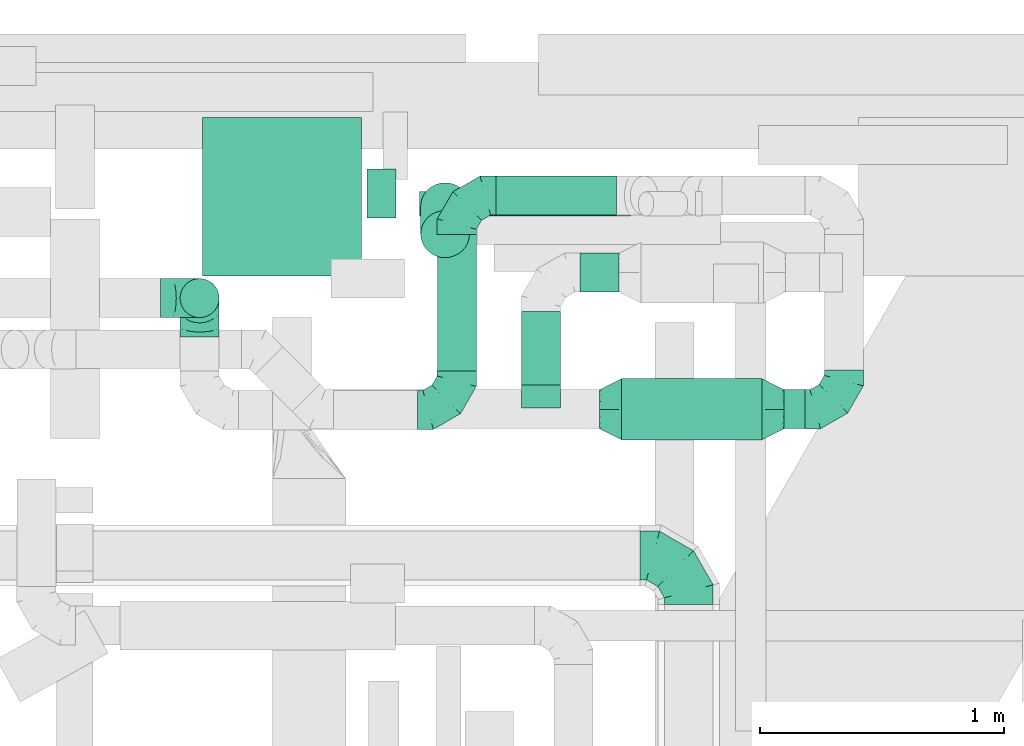
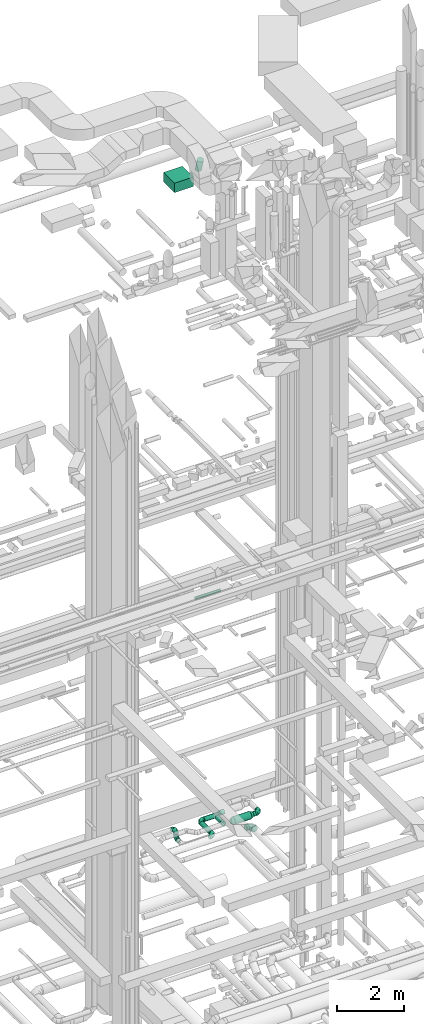
# One storey, part 287 of 337: 11 flow segments, 9 flow fittings.
"""IFC2X3 building model written with IfcOpenShell, lengths in millimetres."""

from ifc_helpers import new_model, entity, si_unit, converted_unit, derived_unit, direction, frame, origin, origin_2d_with_axis, place, context, subcontext, project, spatial, rectangle, circle, extrude, faceted_brep, source, transform, mapped, material, type_object, type_shapes, element, save


model = new_model("IFC2X3")

# Units and contexts
model_context = context("Model", 3, precision=0.01, world=origin(), true_north=direction((6.12303176911189e-17, 1.0)))
body_context = subcontext(model_context, "Body", "Model", "MODEL_VIEW")
ifc_project = project(units=[si_unit("LENGTHUNIT", "METRE", prefix="MILLI"), si_unit("AREAUNIT", "SQUARE_METRE"), si_unit("VOLUMEUNIT", "CUBIC_METRE"), converted_unit("PLANEANGLEUNIT", "DEGREE", entity("IfcRatioMeasure", 0.0174532925199433), si_unit("PLANEANGLEUNIT", "RADIAN"), dimensions=[0, 0, 0, 0, 0, 0, 0]), si_unit("MASSUNIT", "GRAM", prefix="KILO"), derived_unit("MASSDENSITYUNIT", [(si_unit("MASSUNIT", "GRAM", prefix="KILO"), 1), (si_unit("LENGTHUNIT", "METRE"), -3)]), derived_unit("MOMENTOFINERTIAUNIT", [(si_unit("LENGTHUNIT", "METRE"), 4)]), si_unit("TIMEUNIT", "SECOND"), si_unit("FREQUENCYUNIT", "HERTZ"), si_unit("THERMODYNAMICTEMPERATUREUNIT", "DEGREE_CELSIUS"), derived_unit("THERMALTRANSMITTANCEUNIT", [(si_unit("MASSUNIT", "GRAM", prefix="KILO"), 1), (si_unit("THERMODYNAMICTEMPERATUREUNIT", "KELVIN"), -1), (si_unit("TIMEUNIT", "SECOND"), -3)]), derived_unit("VOLUMETRICFLOWRATEUNIT", [(si_unit("LENGTHUNIT", "METRE"), 3), (si_unit("TIMEUNIT", "SECOND"), -1)]), derived_unit("MASSFLOWRATEUNIT", [(si_unit("MASSUNIT", "GRAM", prefix="KILO"), 1), (si_unit("TIMEUNIT", "SECOND"), -1)]), derived_unit("ROTATIONALFREQUENCYUNIT", [(si_unit("TIMEUNIT", "SECOND"), -1)]), si_unit("ELECTRICCURRENTUNIT", "AMPERE"), si_unit("ELECTRICVOLTAGEUNIT", "VOLT"), si_unit("POWERUNIT", "WATT"), si_unit("FORCEUNIT", "NEWTON", prefix="KILO"), si_unit("ILLUMINANCEUNIT", "LUX"), si_unit("LUMINOUSFLUXUNIT", "LUMEN"), si_unit("LUMINOUSINTENSITYUNIT", "CANDELA"), derived_unit("USERDEFINED", [(si_unit("MASSUNIT", "GRAM", prefix="KILO"), -1), (si_unit("LENGTHUNIT", "METRE"), -2), (si_unit("TIMEUNIT", "SECOND"), 3), (si_unit("LUMINOUSFLUXUNIT", "LUMEN"), 1)]), derived_unit("LINEARVELOCITYUNIT", [(si_unit("LENGTHUNIT", "METRE"), 1), (si_unit("TIMEUNIT", "SECOND"), -1)]), si_unit("PRESSUREUNIT", "PASCAL"), derived_unit("USERDEFINED", [(si_unit("LENGTHUNIT", "METRE"), -2), (si_unit("MASSUNIT", "GRAM", prefix="KILO"), 1), (si_unit("TIMEUNIT", "SECOND"), -2)]), derived_unit("LINEARFORCEUNIT", [(si_unit("MASSUNIT", "GRAM", prefix="KILO"), 1), (si_unit("LENGTHUNIT", "METRE"), 1), (si_unit("TIMEUNIT", "SECOND"), -2), (si_unit("LENGTHUNIT", "METRE"), -1)]), derived_unit("PLANARFORCEUNIT", [(si_unit("MASSUNIT", "GRAM", prefix="KILO"), 1), (si_unit("LENGTHUNIT", "METRE"), 1), (si_unit("TIMEUNIT", "SECOND"), -2), (si_unit("LENGTHUNIT", "METRE"), -2)])], contexts=[model_context])

# Site, building, storey
site_placement = place(None, origin())
site = spatial("IfcSite", under=ifc_project, at=site_placement, CompositionType="ELEMENT")
building_placement = place(site_placement, origin())
building = spatial("IfcBuilding", under=site, at=building_placement, CompositionType="ELEMENT")
storey_placement = place(building_placement, origin())
storey = spatial("IfcBuildingStorey", under=building, at=storey_placement, CompositionType="ELEMENT", Elevation=0.0)

# Flow segments
duct_segment_type_1 = type_object("IfcDuctSegmentType", PredefinedType="NOTDEFINED")
flow_segment_1_placement = place(storey_placement, frame((51398.48, 19108.98, 26700.0)))
element("IfcFlowSegment", 1, at=flow_segment_1_placement, inside=storey, type_object=duct_segment_type_1, context=body_context, shape_type="SweptSolid", body=[
    extrude(rectangle(XDim=650.0, YDim=650.0, at=origin_2d_with_axis()), frame((325.0, 325.0, 0.0)), (0.0, 0.0, 1.0), 349.999999999998),
])
duct_segment_type_2 = type_object("IfcDuctSegmentType", PredefinedType="NOTDEFINED")
flow_segment_2_placement = place(storey_placement, frame((52285.9, 19353.19, 11348.4)))
element("IfcFlowSegment", 2, at=flow_segment_2_placement, inside=storey, type_object=duct_segment_type_2, context=body_context, shape_type="SweptSolid", body=[
    extrude(circle(Radius=50.0, at=origin_2d_with_axis()), frame((0.0, 51.6, 51.6), z_axis=(1.0, 0.0, 0.0), x_axis=(0.0, 1.0, 0.0)), (0.0, 0.0, 1.0), 864.588142746948),
])
flow_segment_3_placement = place(storey_placement, frame((52289.06, 19183.14, 27014.73)))
element("IfcFlowSegment", 3, at=flow_segment_3_placement, inside=storey, type_object=duct_segment_type_2, context=body_context, shape_type="SweptSolid", body=[
    extrude(circle(Radius=100.0, at=origin_2d_with_axis()), frame((101.6, 211.95, 28.11), z_axis=(0.0, -0.265156483021046, 0.964205392803789), x_axis=(0.0, 0.964205392803789, 0.265156483021046)), (0.0, 0.0, 1.0), 429.698740507696),
])
flow_segment_4_placement = place(storey_placement, frame((52070.65, 19346.53, 26748.4)))
element("IfcFlowSegment", 4, at=flow_segment_4_placement, inside=storey, type_object=duct_segment_type_2, context=body_context, shape_type="SweptSolid", body=[
    extrude(circle(Radius=100.0, at=origin_2d_with_axis()), frame((0.0, 101.6, 101.6), z_axis=(1.0, 0.0, 0.0), x_axis=(0.0, 1.0, 0.0)), (0.0, 0.0, 1.0), 119.999999999999),
])
flow_segment_5_placement = place(storey_placement, frame((52356.74, 18721.61, 3118.4)))
element("IfcFlowSegment", 5, at=flow_segment_5_placement, inside=storey, type_object=duct_segment_type_2, context=body_context, shape_type="SweptSolid", body=[
    extrude(circle(Radius=80.0, at=origin_2d_with_axis()), frame((81.6, 0.0, 81.6), z_axis=(0.0, 1.0, 0.0), x_axis=(1.0, 0.0, 0.0)), (0.0, 0.0, 1.0), 557.500000000003),
])
flow_segment_6_placement = place(storey_placement, frame((51304.24, 18937.52, 3360.0)))
element("IfcFlowSegment", 6, at=flow_segment_6_placement, inside=storey, type_object=duct_segment_type_2, context=body_context, shape_type="SweptSolid", body=[
    extrude(circle(Radius=80.0, at=origin_2d_with_axis()), frame((81.6, 81.6, 0.0)), (0.0, 0.0, 1.0), 30.0000000000083),
])
flow_segment_7_placement = place(storey_placement, frame((52598.34, 19357.52, 3118.4)))
element("IfcFlowSegment", 7, at=flow_segment_7_placement, inside=storey, type_object=duct_segment_type_2, context=body_context, shape_type="SweptSolid", body=[
    extrude(circle(Radius=80.0, at=origin_2d_with_axis()), frame((0.0, 81.6, 81.6), z_axis=(1.0, 0.0, 0.0), x_axis=(0.0, -1.0, 0.0)), (0.0, 0.0, 1.0), 493.725830020317),
])
flow_segment_8_placement = place(storey_placement, frame((53778.34, 18482.52, 3418.4)))
element("IfcFlowSegment", 8, at=flow_segment_8_placement, inside=storey, type_object=duct_segment_type_2, context=body_context, shape_type="SweptSolid", body=[
    extrude(circle(Radius=80.0, at=origin_2d_with_axis()), frame((0.0, 81.6, 81.6), z_axis=(1.0, 0.0, 0.0), x_axis=(0.0, 1.0, 0.0)), (0.0, 0.0, 1.0), 85.0000000000153),
])
flow_segment_9_placement = place(storey_placement, frame((53113.34, 18437.52, 3373.4)))
element("IfcFlowSegment", 9, at=flow_segment_9_placement, inside=storey, type_object=duct_segment_type_2, context=body_context, shape_type="SweptSolid", body=[
    extrude(circle(Radius=125.0, at=origin_2d_with_axis()), frame((0.0, 126.6, 126.6), z_axis=(1.0, 0.0, 0.0), x_axis=(0.0, 1.0, 0.0)), (0.0, 0.0, 1.0), 574.999999999991),
])
flow_segment_10_placement = place(storey_placement, frame((52943.34, 19041.81, 3418.4)))
element("IfcFlowSegment", 10, at=flow_segment_10_placement, inside=storey, type_object=duct_segment_type_2, context=body_context, shape_type="SweptSolid", body=[
    extrude(circle(Radius=80.0, at=origin_2d_with_axis()), frame((0.0, 81.6, 81.6), z_axis=(1.0, 0.0, 0.0), x_axis=(0.0, 1.0, 0.0)), (0.0, 0.0, 1.0), 160.000000000016),
])
flow_segment_11_placement = place(storey_placement, frame((52701.74, 18664.11, 3418.4)))
element("IfcFlowSegment", 11, at=flow_segment_11_placement, inside=storey, type_object=duct_segment_type_2, context=body_context, shape_type="SweptSolid", body=[
    extrude(circle(Radius=80.0, at=origin_2d_with_axis()), frame((81.6, 0.0, 81.6), z_axis=(0.0, 1.0, 0.0), x_axis=(-1.0, 0.0, 0.0)), (0.0, 0.0, 1.0), 299.297970592642),
])

# Flow fittings
ifc_material = material()
duct_fitting_type_1 = type_object("IfcDuctFittingType", PredefinedType="NOTDEFINED", material=ifc_material)
shared_shape_1 = source(origin(), body_context, "Body", "Brep", [
    faceted_brep([(-160.0, 0.0, -80.0), (-160.0, -20.71, -77.27), (-160.0, -40.0, -69.28), (-160.0, -56.57, -56.57), (-160.0, -69.28, -40.0), (-160.0, -77.27, -20.71), (-160.0, -80.0, 0.0), (-160.0, -77.27, 20.71), (-160.0, -69.28, 40.0), (-160.0, -56.57, 56.57), (-160.0, -40.0, 69.28), (-160.0, -20.71, 77.27), (-160.0, 0.0, 80.0), (-160.0, 20.71, 77.27), (-160.0, 40.0, 69.28), (-160.0, 56.57, 56.57), (-160.0, 69.28, 40.0), (-160.0, 77.27, 20.71), (-160.0, 80.0, 0.0), (-160.0, 77.27, -20.71), (-160.0, 69.28, -40.0), (-160.0, 56.57, -56.57), (-160.0, 40.0, -69.28), (-160.0, 20.71, -77.27), (-122.68, 20.71, 77.27), (-127.85, 40.0, 69.28), (-117.13, 0.0, 80.0), (-132.29, 56.57, 56.57), (-137.83, 77.27, 20.71), (-138.56, 80.0, 0.0), (-135.69, 69.28, 40.0), (-135.69, 69.28, -40.0), (-132.29, 56.57, -56.57), (-137.83, 77.27, -20.71), (-122.68, 20.71, -77.27), (-117.13, 0.0, -80.0), (-127.85, 40.0, -69.28), (-111.58, -20.71, -77.27), (-106.41, -40.0, -69.28), (-101.97, -56.57, -56.57), (-98.56, -69.28, -40.0), (-96.42, -77.27, -20.71), (-95.69, -80.0, 0.0), (-96.42, -77.27, 20.71), (-98.56, -69.28, 40.0), (-101.97, -56.57, 56.57), (-106.41, -40.0, 69.28), (-111.58, -20.71, 77.27), (-58.03, 58.03, 77.27), (-72.15, 72.15, 69.28), (-42.87, 42.87, 80.0), (-84.28, 84.28, 56.57), (-93.59, 93.59, 40.0), (-99.44, 99.44, 20.71), (-101.44, 101.44, 0.0), (-99.44, 99.44, -20.71), (-93.59, 93.59, -40.0), (-84.28, 84.28, -56.57), (-58.03, 58.03, -77.27), (-42.87, 42.87, -80.0), (-72.15, 72.15, -69.28), (-27.71, 27.71, -77.27), (-13.59, 13.59, -69.28), (-1.46, 1.46, -56.57), (7.85, -7.85, -40.0), (13.7, -13.7, -20.71), (15.69, -15.69, 0.0), (13.7, -13.7, 20.71), (7.85, -7.85, 40.0), (-1.46, 1.46, 56.57), (-13.59, 13.59, 69.28), (-27.71, 27.71, 77.27), (-20.71, 122.68, 77.27), (-40.0, 127.85, 69.28), (0.0, 117.13, 80.0), (-56.57, 132.29, 56.57), (-69.28, 135.69, 40.0), (-77.27, 137.83, 20.71), (-80.0, 138.56, 0.0), (-77.27, 137.83, -20.71), (-69.28, 135.69, -40.0), (-56.57, 132.29, -56.57), (-20.71, 122.68, -77.27), (0.0, 117.13, -80.0), (-40.0, 127.85, -69.28), (20.71, 111.58, -77.27), (40.0, 106.41, -69.28), (56.57, 101.97, -56.57), (69.28, 98.56, -40.0), (77.27, 96.42, -20.71), (80.0, 95.69, 0.0), (77.27, 96.42, 20.71), (69.28, 98.56, 40.0), (56.57, 101.97, 56.57), (40.0, 106.41, 69.28), (20.71, 111.58, 77.27), (-20.71, 160.0, -77.27), (-40.0, 160.0, -69.28), (-56.57, 160.0, -56.57), (-69.28, 160.0, -40.0), (-77.27, 160.0, -20.71), (-80.0, 160.0, 0.0), (-77.27, 160.0, 20.71), (-69.28, 160.0, 40.0), (-56.57, 160.0, 56.57), (-40.0, 160.0, 69.28), (-20.71, 160.0, 77.27), (0.0, 160.0, 80.0), (20.71, 160.0, 77.27), (40.0, 160.0, 69.28), (56.57, 160.0, 56.57), (69.28, 160.0, 40.0), (77.27, 160.0, 20.71), (80.0, 160.0, 0.0), (77.27, 160.0, -20.71), (69.28, 160.0, -40.0), (56.57, 160.0, -56.57), (40.0, 160.0, -69.28), (20.71, 160.0, -77.27), (0.0, 160.0, -80.0)], [[[0, 1, 2, 3, 4, 5, 6, 7, 8, 9, 10, 11, 12, 13, 14, 15, 16, 17, 18, 19, 20, 21, 22, 23]], [[24, 25, 14, 13]], [[26, 24, 13, 12]], [[14, 25, 27, 15]], [[28, 29, 18, 17]], [[30, 28, 17, 16]], [[15, 27, 30, 16]], [[20, 31, 32, 21]], [[33, 31, 20, 19]], [[18, 29, 33, 19]], [[34, 35, 0, 23]], [[36, 34, 23, 22]], [[32, 36, 22, 21]], [[1, 0, 35, 37]], [[2, 1, 37, 38]], [[3, 2, 38, 39]], [[5, 4, 40, 41]], [[6, 5, 41, 42]], [[39, 40, 4, 3]], [[6, 42, 43, 7]], [[7, 43, 44, 8]], [[8, 44, 45, 9]], [[9, 45, 46, 10]], [[10, 46, 47, 11]], [[26, 12, 11, 47]], [[48, 49, 25, 24]], [[50, 48, 24, 26]], [[27, 25, 49, 51]], [[52, 53, 28, 30]], [[51, 52, 30, 27]], [[29, 28, 53, 54]], [[55, 56, 31, 33]], [[54, 55, 33, 29]], [[32, 31, 56, 57]], [[58, 59, 35, 34]], [[60, 58, 34, 36]], [[57, 60, 36, 32]], [[37, 35, 59, 61]], [[38, 37, 61, 62]], [[39, 38, 62, 63]], [[41, 40, 64, 65]], [[42, 41, 65, 66]], [[63, 64, 40, 39]], [[43, 42, 66, 67]], [[44, 43, 67, 68]], [[68, 69, 45, 44]], [[46, 45, 69, 70]], [[47, 46, 70, 71]], [[26, 47, 71, 50]], [[72, 73, 49, 48]], [[74, 72, 48, 50]], [[51, 49, 73, 75]], [[76, 77, 53, 52]], [[75, 76, 52, 51]], [[54, 53, 77, 78]], [[79, 80, 56, 55]], [[78, 79, 55, 54]], [[57, 56, 80, 81]], [[82, 83, 59, 58]], [[84, 82, 58, 60]], [[81, 84, 60, 57]], [[61, 59, 83, 85]], [[62, 61, 85, 86]], [[63, 62, 86, 87]], [[65, 64, 88, 89]], [[66, 65, 89, 90]], [[87, 88, 64, 63]], [[67, 66, 90, 91]], [[68, 67, 91, 92]], [[92, 93, 69, 68]], [[70, 69, 93, 94]], [[71, 70, 94, 95]], [[50, 71, 95, 74]], [[96, 97, 98, 99, 100, 101, 102, 103, 104, 105, 106, 107, 108, 109, 110, 111, 112, 113, 114, 115, 116, 117, 118, 119]], [[72, 74, 107, 106]], [[73, 72, 106, 105]], [[75, 73, 105, 104]], [[77, 76, 103, 102]], [[78, 77, 102, 101]], [[75, 104, 103, 76]], [[78, 101, 100, 79]], [[79, 100, 99, 80]], [[80, 99, 98, 81]], [[84, 97, 96, 82]], [[82, 96, 119, 83]], [[84, 81, 98, 97]], [[118, 117, 86, 85]], [[119, 118, 85, 83]], [[116, 87, 86, 117]], [[88, 115, 114, 89]], [[89, 114, 113, 90]], [[115, 88, 87, 116]], [[112, 111, 92, 91]], [[113, 112, 91, 90]], [[111, 110, 93, 92]], [[95, 94, 109, 108]], [[74, 95, 108, 107]], [[110, 109, 94, 93]]]),
])
type_shapes(duct_fitting_type_1, [shared_shape_1])
flow_fitting_1_placement = place(storey_placement, frame((52438.34, 18561.61, 3200.0)))
element("IfcFlowFitting", 12, at=flow_fitting_1_placement, inside=storey, type_object=duct_fitting_type_1, material=ifc_material, context=body_context, shape_type="MappedRepresentation", body=[
    mapped(shared_shape_1, transform((0.0, 0.0, 0.0), scale=1.0)),
])
for number, where, z_axis, x_axis in (
    (13, (52438.34, 19439.11, 3200.0), (0.0, 0.0, 1.0), (-1.0, 0.0, 0.0)),
    (14, (51385.84, 19019.11, 3550.0), (0.0, 1.0, 0.0), (1.0, 0.0, 0.0)),
    (15, (51385.84, 19019.11, 3200.0), (1.0, 0.0, 0.0), (0.0, 1.0, 0.0)),
):
    element("IfcFlowFitting", number, at=place(storey_placement, frame(where, z_axis=z_axis, x_axis=x_axis)), inside=storey, type_object=duct_fitting_type_1, material=ifc_material, context=body_context, shape_type="MappedRepresentation", body=[
        mapped(shared_shape_1, transform((0.0, 0.0, 0.0), scale=1.0)),
    ])
flow_fitting_2_placement = place(storey_placement, frame((54023.34, 18564.11, 3500.0)))
element("IfcFlowFitting", 16, at=flow_fitting_2_placement, inside=storey, type_object=duct_fitting_type_1, material=ifc_material, context=body_context, shape_type="MappedRepresentation", body=[
    mapped(shared_shape_1, transform((0.0, 0.0, 0.0), scale=1.0)),
])
duct_fitting_type_2 = type_object("IfcDuctFittingType", PredefinedType="NOTDEFINED", material=ifc_material)
shared_shape_2 = source(origin(), body_context, "Body", "Brep", [
    faceted_brep([(-200.0, 0.0, -100.0), (-200.0, -25.88, -96.59), (-200.0, -50.0, -86.6), (-200.0, -70.71, -70.71), (-200.0, -86.6, -50.0), (-200.0, -96.59, -25.88), (-200.0, -100.0, 0.0), (-200.0, -96.59, 25.88), (-200.0, -86.6, 50.0), (-200.0, -70.71, 70.71), (-200.0, -50.0, 86.6), (-200.0, -25.88, 96.59), (-200.0, 0.0, 100.0), (-200.0, 25.88, 96.59), (-200.0, 50.0, 86.6), (-200.0, 70.71, 70.71), (-200.0, 86.6, 50.0), (-200.0, 96.59, 25.88), (-200.0, 100.0, 0.0), (-200.0, 96.59, -25.88), (-200.0, 86.6, -50.0), (-200.0, 70.71, -70.71), (-200.0, 50.0, -86.6), (-200.0, 25.88, -96.59), (-153.35, 25.88, 96.59), (-159.81, 50.0, 86.6), (-146.41, 0.0, 100.0), (-165.36, 70.71, 70.71), (-172.29, 96.59, 25.88), (-173.21, 100.0, 0.0), (-169.62, 86.6, 50.0), (-169.62, 86.6, -50.0), (-165.36, 70.71, -70.71), (-172.29, 96.59, -25.88), (-153.35, 25.88, -96.59), (-146.41, 0.0, -100.0), (-159.81, 50.0, -86.6), (-139.48, -25.88, -96.59), (-133.01, -50.0, -86.6), (-127.46, -70.71, -70.71), (-123.21, -86.6, -50.0), (-120.53, -96.59, -25.88), (-119.62, -100.0, 0.0), (-120.53, -96.59, 25.88), (-123.21, -86.6, 50.0), (-127.46, -70.71, 70.71), (-133.01, -50.0, 86.6), (-139.48, -25.88, 96.59), (-72.54, 72.54, 96.59), (-90.19, 90.19, 86.6), (-53.59, 53.59, 100.0), (-105.35, 105.35, 70.71), (-116.99, 116.99, 50.0), (-124.3, 124.3, 25.88), (-126.79, 126.79, 0.0), (-124.3, 124.3, -25.88), (-116.99, 116.99, -50.0), (-105.35, 105.35, -70.71), (-72.54, 72.54, -96.59), (-53.59, 53.59, -100.0), (-90.19, 90.19, -86.6), (-34.64, 34.64, -96.59), (-16.99, 16.99, -86.6), (-1.83, 1.83, -70.71), (9.81, -9.81, -50.0), (17.12, -17.12, -25.88), (19.62, -19.62, 0.0), (17.12, -17.12, 25.88), (9.81, -9.81, 50.0), (-1.83, 1.83, 70.71), (-16.99, 16.99, 86.6), (-34.64, 34.64, 96.59), (-25.88, 153.35, 96.59), (-50.0, 159.81, 86.6), (0.0, 146.41, 100.0), (-70.71, 165.36, 70.71), (-86.6, 169.62, 50.0), (-96.59, 172.29, 25.88), (-100.0, 173.21, 0.0), (-96.59, 172.29, -25.88), (-86.6, 169.62, -50.0), (-70.71, 165.36, -70.71), (-25.88, 153.35, -96.59), (0.0, 146.41, -100.0), (-50.0, 159.81, -86.6), (25.88, 139.48, -96.59), (50.0, 133.01, -86.6), (70.71, 127.46, -70.71), (86.6, 123.21, -50.0), (96.59, 120.53, -25.88), (100.0, 119.62, 0.0), (96.59, 120.53, 25.88), (86.6, 123.21, 50.0), (70.71, 127.46, 70.71), (50.0, 133.01, 86.6), (25.88, 139.48, 96.59), (-25.88, 200.0, -96.59), (-50.0, 200.0, -86.6), (-70.71, 200.0, -70.71), (-86.6, 200.0, -50.0), (-96.59, 200.0, -25.88), (-100.0, 200.0, 0.0), (-96.59, 200.0, 25.88), (-86.6, 200.0, 50.0), (-70.71, 200.0, 70.71), (-50.0, 200.0, 86.6), (-25.88, 200.0, 96.59), (0.0, 200.0, 100.0), (25.88, 200.0, 96.59), (50.0, 200.0, 86.6), (70.71, 200.0, 70.71), (86.6, 200.0, 50.0), (96.59, 200.0, 25.88), (100.0, 200.0, 0.0), (96.59, 200.0, -25.88), (86.6, 200.0, -50.0), (70.71, 200.0, -70.71), (50.0, 200.0, -86.6), (25.88, 200.0, -96.59), (0.0, 200.0, -100.0)], [[[0, 1, 2, 3, 4, 5, 6, 7, 8, 9, 10, 11, 12, 13, 14, 15, 16, 17, 18, 19, 20, 21, 22, 23]], [[24, 25, 14, 13]], [[26, 24, 13, 12]], [[14, 25, 27, 15]], [[28, 29, 18, 17]], [[30, 28, 17, 16]], [[15, 27, 30, 16]], [[20, 31, 32, 21]], [[33, 31, 20, 19]], [[18, 29, 33, 19]], [[34, 35, 0, 23]], [[36, 34, 23, 22]], [[32, 36, 22, 21]], [[1, 0, 35, 37]], [[2, 1, 37, 38]], [[38, 39, 3, 2]], [[5, 4, 40, 41]], [[6, 5, 41, 42]], [[39, 40, 4, 3]], [[6, 42, 43, 7]], [[7, 43, 44, 8]], [[8, 44, 45, 9]], [[9, 45, 46, 10]], [[10, 46, 47, 11]], [[26, 12, 11, 47]], [[48, 49, 25, 24]], [[50, 48, 24, 26]], [[27, 25, 49, 51]], [[52, 53, 28, 30]], [[51, 52, 30, 27]], [[29, 28, 53, 54]], [[55, 56, 31, 33]], [[54, 55, 33, 29]], [[32, 31, 56, 57]], [[58, 59, 35, 34]], [[60, 58, 34, 36]], [[57, 60, 36, 32]], [[37, 35, 59, 61]], [[38, 37, 61, 62]], [[39, 38, 62, 63]], [[41, 40, 64, 65]], [[42, 41, 65, 66]], [[63, 64, 40, 39]], [[43, 42, 66, 67]], [[44, 43, 67, 68]], [[68, 69, 45, 44]], [[46, 45, 69, 70]], [[47, 46, 70, 71]], [[26, 47, 71, 50]], [[72, 73, 49, 48]], [[74, 72, 48, 50]], [[51, 49, 73, 75]], [[76, 77, 53, 52]], [[75, 76, 52, 51]], [[54, 53, 77, 78]], [[79, 80, 56, 55]], [[78, 79, 55, 54]], [[57, 56, 80, 81]], [[82, 83, 59, 58]], [[84, 82, 58, 60]], [[81, 84, 60, 57]], [[61, 59, 83, 85]], [[62, 61, 85, 86]], [[63, 62, 86, 87]], [[65, 64, 88, 89]], [[66, 65, 89, 90]], [[87, 88, 64, 63]], [[67, 66, 90, 91]], [[68, 67, 91, 92]], [[92, 93, 69, 68]], [[70, 69, 93, 94]], [[71, 70, 94, 95]], [[50, 71, 95, 74]], [[96, 97, 98, 99, 100, 101, 102, 103, 104, 105, 106, 107, 108, 109, 110, 111, 112, 113, 114, 115, 116, 117, 118, 119]], [[72, 74, 107, 106]], [[73, 72, 106, 105]], [[75, 73, 105, 104]], [[102, 101, 78, 77]], [[103, 102, 77, 76]], [[75, 104, 103, 76]], [[78, 101, 100, 79]], [[79, 100, 99, 80]], [[80, 99, 98, 81]], [[84, 97, 96, 82]], [[82, 96, 119, 83]], [[84, 81, 98, 97]], [[118, 117, 86, 85]], [[119, 118, 85, 83]], [[116, 87, 86, 117]], [[88, 115, 114, 89]], [[89, 114, 113, 90]], [[115, 88, 87, 116]], [[91, 90, 113, 112]], [[92, 91, 112, 111]], [[111, 110, 93, 92]], [[95, 94, 109, 108]], [[74, 95, 108, 107]], [[110, 109, 94, 93]]]),
])
type_shapes(duct_fitting_type_2, [shared_shape_2])
flow_fitting_3_placement = place(storey_placement, frame((53388.27, 17965.07, 3580.0), z_axis=(0.0, 0.0, 1.0), x_axis=(0.0, 1.0, 0.0)))
element("IfcFlowFitting", 17, at=flow_fitting_3_placement, inside=storey, type_object=duct_fitting_type_2, material=ifc_material, context=body_context, shape_type="MappedRepresentation", body=[
    mapped(shared_shape_2, transform((0.0, 0.0, 0.0), scale=1.0)),
])
duct_fitting_type_3 = type_object("IfcDuctFittingType", PredefinedType="NOTDEFINED", material=ifc_material)
shared_shape_3 = source(origin(), body_context, "Body", "Brep", [
    faceted_brep([(90.0, -73.91, 30.61), (90.0, -76.96, 15.31), (90.0, -80.0, 0.0), (90.0, -76.96, -15.31), (90.0, -73.91, -30.61), (90.0, -65.24, -43.59), (90.0, -56.57, -56.57), (90.0, -43.59, -65.24), (90.0, -30.61, -73.91), (90.0, -15.31, -76.96), (90.0, 0.0, -80.0), (90.0, 15.31, -76.96), (90.0, 30.61, -73.91), (90.0, 43.59, -65.24), (90.0, 56.57, -56.57), (90.0, 65.24, -43.59), (90.0, 73.91, -30.61), (90.0, 76.96, -15.31), (90.0, 80.0, 0.0), (90.0, 76.96, 15.31), (90.0, 73.91, 30.61), (90.0, 65.24, 43.59), (90.0, 56.57, 56.57), (90.0, 43.59, 65.24), (90.0, 30.61, 73.91), (90.0, 15.31, 76.96), (90.0, 0.0, 80.0), (90.0, -15.31, 76.96), (90.0, -30.61, 73.91), (90.0, -43.59, 65.24), (90.0, -56.57, 56.57), (90.0, -65.24, 43.59), (0.0, -125.0, 0.0), (0.0, -118.88, 38.63), (0.0, -101.13, 73.47), (0.0, -73.47, 101.13), (0.0, -38.63, 118.88), (0.0, 0.0, 125.0), (0.0, 38.63, 118.88), (0.0, 73.47, 101.13), (0.0, 101.13, 73.47), (0.0, 118.88, 38.63), (0.0, 125.0, 0.0), (0.0, 118.88, -38.63), (0.0, 101.13, -73.47), (0.0, 73.47, -101.13), (0.0, 38.63, -118.88), (0.0, 0.0, -125.0), (0.0, -38.63, -118.88), (0.0, -73.47, -101.13), (0.0, -101.13, -73.47), (0.0, -118.88, -38.63)], [[[0, 1, 2, 3, 4, 5, 6, 7, 8, 9, 10, 11, 12, 13, 14, 15, 16, 17, 18, 19, 20, 21, 22, 23, 24, 25, 26, 27, 28, 29, 30, 31]], [[32, 33, 34, 35, 36, 37, 38, 39, 40, 41, 42, 43, 44, 45, 46, 47, 48, 49, 50, 51]], [[37, 25, 38]], [[24, 39, 38]], [[40, 22, 21, 20]], [[23, 22, 39, 24]], [[41, 20, 19]], [[18, 42, 19]], [[25, 24, 38]], [[40, 20, 41]], [[19, 42, 41]], [[25, 37, 26]], [[22, 40, 39]], [[32, 1, 33]], [[0, 34, 33]], [[35, 30, 29, 28]], [[31, 30, 34, 0]], [[36, 28, 27]], [[26, 37, 27]], [[1, 0, 33]], [[35, 28, 36]], [[27, 37, 36]], [[1, 32, 2]], [[30, 35, 34]], [[47, 9, 48]], [[8, 49, 48]], [[50, 6, 5, 4]], [[7, 6, 49, 8]], [[51, 4, 3]], [[2, 32, 3]], [[9, 8, 48]], [[50, 4, 51]], [[3, 32, 51]], [[9, 47, 10]], [[6, 50, 49]], [[42, 17, 43]], [[16, 44, 43]], [[45, 14, 13, 12]], [[15, 14, 44, 16]], [[46, 12, 11]], [[10, 47, 11]], [[17, 16, 43]], [[45, 12, 46]], [[11, 47, 46]], [[17, 42, 18]], [[14, 45, 44]]]),
])
type_shapes(duct_fitting_type_3, [shared_shape_3])
flow_fitting_4_placement = place(storey_placement, frame((53113.34, 18564.11, 3500.0), z_axis=(0.0, 0.0, 1.0), x_axis=(-1.0, 0.0, 0.0)))
element("IfcFlowFitting", 18, at=flow_fitting_4_placement, inside=storey, type_object=duct_fitting_type_3, material=ifc_material, context=body_context, shape_type="MappedRepresentation", body=[
    mapped(shared_shape_3, transform((0.0, 0.0, 0.0), scale=1.0)),
])
duct_fitting_type_4 = type_object("IfcDuctFittingType", PredefinedType="NOTDEFINED", material=ifc_material)
shared_shape_4 = source(origin(), body_context, "Body", "Brep", [
    faceted_brep([(20.0, 20.71, -77.27), (20.0, 40.0, -69.28), (20.0, 56.57, -56.57), (20.0, 69.28, -40.0), (20.0, 77.27, -20.71), (20.0, 80.0, 0.0), (20.0, 77.27, 20.71), (20.0, 69.28, 40.0), (20.0, 56.57, 56.57), (20.0, 40.0, 69.28), (20.0, 20.71, 77.27), (20.0, 0.0, 80.0), (20.0, -20.71, 77.27), (20.0, -40.0, 69.28), (20.0, -56.57, 56.57), (20.0, -69.28, 40.0), (20.0, -77.27, 20.71), (20.0, -80.0, 0.0), (20.0, -77.27, -20.71), (20.0, -69.28, -40.0), (20.0, -56.57, -56.57), (20.0, -40.0, -69.28), (20.0, -20.71, -77.27), (20.0, 0.0, -80.0), (0.0, 0.0, 80.0), (0.0, 20.71, 77.27), (-73.9, 20.71, 77.27), (-73.9, 0.0, 80.0), (0.0, 40.0, 69.28), (-73.9, 40.0, 69.28), (0.0, 56.57, 56.57), (-73.9, 56.57, 56.57), (0.0, 69.28, 40.0), (0.0, 77.27, 20.71), (-73.9, 77.27, 20.71), (-73.9, 69.28, 40.0), (0.0, 80.0, 0.0), (-73.9, 80.0, 0.0), (0.0, 77.27, -20.71), (-73.9, 77.27, -20.71), (0.0, 69.28, -40.0), (-73.9, 69.28, -40.0), (0.0, 56.57, -56.57), (-73.9, 56.57, -56.57), (0.0, 40.0, -69.28), (0.0, 20.71, -77.27), (-73.9, 20.71, -77.27), (-73.9, 40.0, -69.28), (0.0, 0.0, -80.0), (-73.9, 0.0, -80.0), (0.0, -20.71, -77.27), (-73.9, -20.71, -77.27), (0.0, -40.0, -69.28), (-73.9, -40.0, -69.28), (0.0, -56.57, -56.57), (-73.9, -56.57, -56.57), (0.0, -69.28, -40.0), (0.0, -77.27, -20.71), (-73.9, -77.27, -20.71), (-73.9, -69.28, -40.0), (0.0, -80.0, 0.0), (-73.9, -80.0, 0.0), (0.0, -77.27, 20.71), (-73.9, -77.27, 20.71), (0.0, -69.28, 40.0), (-73.9, -69.28, 40.0), (0.0, -56.57, 56.57), (-73.9, -56.57, 56.57), (0.0, -40.0, 69.28), (0.0, -20.71, 77.27), (-73.9, -20.71, 77.27), (-73.9, -40.0, 69.28)], [[[0, 1, 2, 3, 4, 5, 6, 7, 8, 9, 10, 11, 12, 13, 14, 15, 16, 17, 18, 19, 20, 21, 22, 23]], [[24, 11, 10, 25, 26, 27]], [[25, 10, 9, 28, 29, 26]], [[28, 9, 8, 30, 31, 29]], [[32, 7, 6, 33, 34, 35]], [[33, 6, 5, 36, 37, 34]], [[30, 8, 7, 32, 35, 31]], [[36, 5, 4, 38, 39, 37]], [[38, 4, 3, 40, 41, 39]], [[40, 3, 2, 42, 43, 41]], [[44, 1, 0, 45, 46, 47]], [[45, 0, 23, 48, 49, 46]], [[42, 2, 1, 44, 47, 43]], [[48, 23, 22, 50, 51, 49]], [[50, 22, 21, 52, 53, 51]], [[52, 21, 20, 54, 55, 53]], [[56, 19, 18, 57, 58, 59]], [[57, 18, 17, 60, 61, 58]], [[54, 20, 19, 56, 59, 55]], [[60, 17, 16, 62, 63, 61]], [[62, 16, 15, 64, 65, 63]], [[64, 15, 14, 66, 67, 65]], [[68, 13, 12, 69, 70, 71]], [[69, 12, 11, 24, 27, 70]], [[66, 14, 13, 68, 71, 67]], [[49, 51, 53, 55, 59, 58, 61, 63, 65, 67, 71, 70, 27, 26, 29, 31, 35, 34, 37, 39, 41, 43, 47, 46]]]),
])
type_shapes(duct_fitting_type_4, [shared_shape_4])
flow_fitting_5_placement = place(storey_placement, frame((52783.34, 18644.11, 3500.0), z_axis=(0.0, 0.0, -1.0), x_axis=(0.0, 1.0, 0.0)))
element("IfcFlowFitting", 19, at=flow_fitting_5_placement, inside=storey, type_object=duct_fitting_type_4, material=ifc_material, context=body_context, shape_type="MappedRepresentation", body=[
    mapped(shared_shape_4, transform((0.0, 0.0, 0.0), scale=1.0)),
])
duct_fitting_type_5 = type_object("IfcDuctFittingType", PredefinedType="NOTDEFINED", material=ifc_material)
shared_shape_5 = source(origin(), body_context, "Body", "Brep", [
    faceted_brep([(90.0, -73.47, -101.13), (90.0, -38.63, -118.88), (90.0, 0.0, -125.0), (90.0, 38.63, -118.88), (90.0, 73.47, -101.13), (90.0, 101.13, -73.47), (90.0, 118.88, -38.63), (90.0, 125.0, 0.0), (90.0, 118.88, 38.63), (90.0, 101.13, 73.47), (90.0, 73.47, 101.13), (90.0, 38.63, 118.88), (90.0, 0.0, 125.0), (90.0, -38.63, 118.88), (90.0, -73.47, 101.13), (90.0, -101.13, 73.47), (90.0, -118.88, 38.63), (90.0, -125.0, 0.0), (90.0, -118.88, -38.63), (90.0, -101.13, -73.47), (0.0, -30.61, -73.91), (0.0, -43.59, -65.24), (0.0, -56.57, -56.57), (0.0, -65.24, -43.59), (0.0, -73.91, -30.61), (0.0, -76.96, -15.31), (0.0, -80.0, 0.0), (0.0, -76.96, 15.31), (0.0, -73.91, 30.61), (0.0, -65.24, 43.59), (0.0, -56.57, 56.57), (0.0, -43.59, 65.24), (0.0, -30.61, 73.91), (0.0, -15.31, 76.96), (0.0, 0.0, 80.0), (0.0, 15.31, 76.96), (0.0, 30.61, 73.91), (0.0, 43.59, 65.24), (0.0, 56.57, 56.57), (0.0, 65.24, 43.59), (0.0, 73.91, 30.61), (0.0, 76.96, 15.31), (0.0, 80.0, 0.0), (0.0, 76.96, -15.31), (0.0, 73.91, -30.61), (0.0, 65.24, -43.59), (0.0, 56.57, -56.57), (0.0, 43.59, -65.24), (0.0, 30.61, -73.91), (0.0, 15.31, -76.96), (0.0, 0.0, -80.0), (0.0, -15.31, -76.96)], [[[0, 1, 2, 3, 4, 5, 6, 7, 8, 9, 10, 11, 12, 13, 14, 15, 16, 17, 18, 19]], [[20, 21, 22, 23, 24, 25, 26, 27, 28, 29, 30, 31, 32, 33, 34, 35, 36, 37, 38, 39, 40, 41, 42, 43, 44, 45, 46, 47, 48, 49, 50, 51]], [[7, 41, 8]], [[41, 40, 8]], [[40, 9, 8]], [[11, 36, 35]], [[41, 7, 42]], [[9, 40, 39, 38]], [[10, 38, 37, 36]], [[12, 35, 34]], [[11, 10, 36]], [[12, 11, 35]], [[38, 10, 9]], [[12, 33, 13]], [[33, 32, 13]], [[32, 14, 13]], [[16, 28, 27]], [[33, 12, 34]], [[14, 32, 31, 30]], [[15, 30, 29, 28]], [[17, 27, 26]], [[16, 15, 28]], [[17, 16, 27]], [[30, 15, 14]], [[17, 25, 18]], [[25, 24, 18]], [[24, 19, 18]], [[1, 20, 51]], [[25, 17, 26]], [[19, 24, 23, 22]], [[0, 22, 21, 20]], [[2, 51, 50]], [[1, 0, 20]], [[2, 1, 51]], [[22, 0, 19]], [[2, 49, 3]], [[49, 48, 3]], [[48, 4, 3]], [[6, 44, 43]], [[49, 2, 50]], [[4, 48, 47, 46]], [[5, 46, 45, 44]], [[7, 43, 42]], [[6, 5, 44]], [[7, 6, 43]], [[46, 5, 4]]]),
])
type_shapes(duct_fitting_type_5, [shared_shape_5])
flow_fitting_6_placement = place(storey_placement, frame((53778.34, 18564.11, 3500.0), z_axis=(0.0, 0.0, 1.0), x_axis=(-1.0, 0.0, 0.0)))
element("IfcFlowFitting", 20, at=flow_fitting_6_placement, inside=storey, type_object=duct_fitting_type_5, material=ifc_material, context=body_context, shape_type="MappedRepresentation", body=[
    mapped(shared_shape_5, transform((0.0, 0.0, 0.0), scale=1.0)),
])

save(model, "model.ifc")
